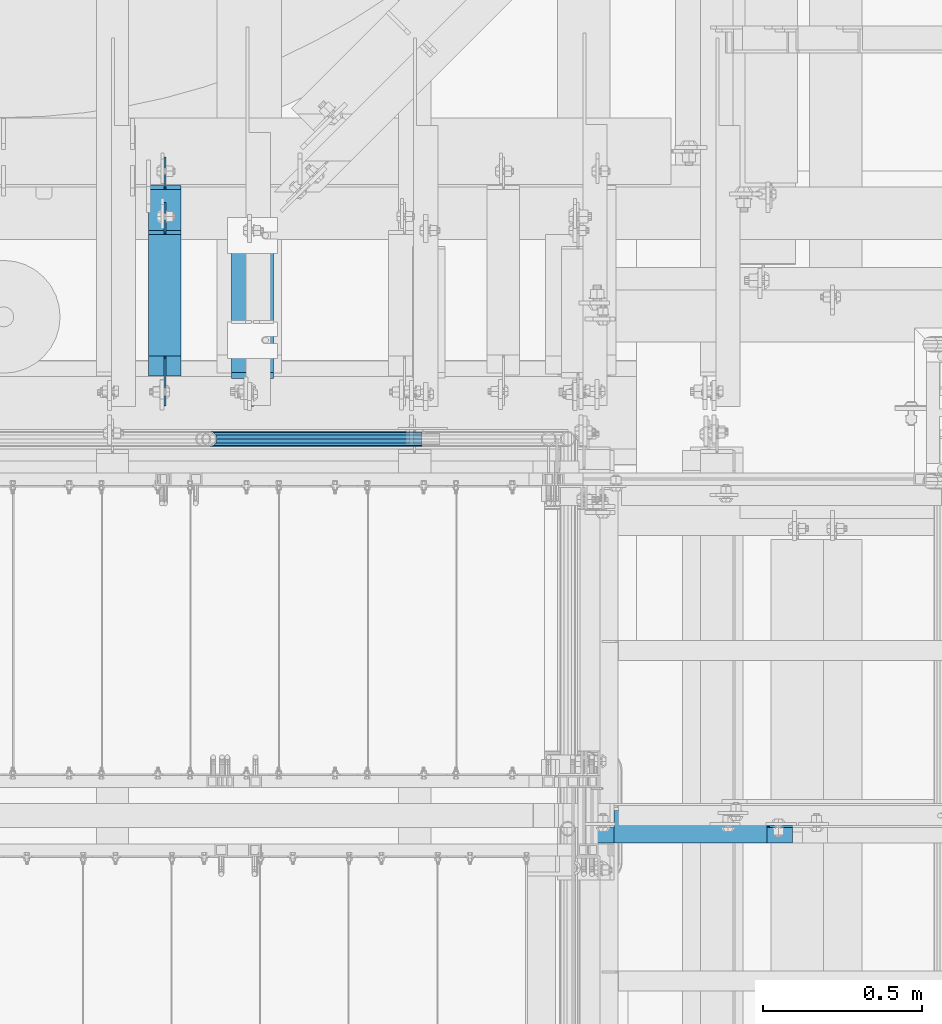
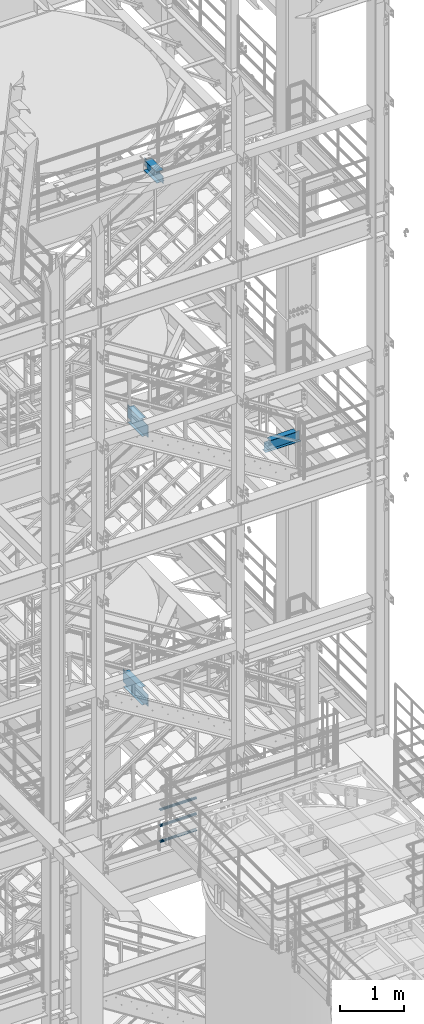
# One storey, part 1194 of 1876: 7 beams, 5 elements without a shape of their own.
"""IFC2X3 building model written with IfcOpenShell, lengths in millimetres."""

from ifc_helpers import new_model, si_unit, frame, origin_with_axes, place, context, subcontext, project, spatial, faceted_brep, material, type_object, element, aggregate, save


model = new_model("IFC2X3")

# Units and contexts
model_context = context("Model", 3, precision=1e-05, world=origin_with_axes())
body_context = subcontext(model_context, "Body", "Model", "MODEL_VIEW")
ifc_project = project(units=[si_unit("LENGTHUNIT", "METRE", prefix="MILLI"), si_unit("AREAUNIT", "SQUARE_METRE"), si_unit("VOLUMEUNIT", "CUBIC_METRE"), si_unit("MASSUNIT", "GRAM", prefix="KILO"), si_unit("TIMEUNIT", "SECOND"), si_unit("PLANEANGLEUNIT", "RADIAN"), si_unit("SOLIDANGLEUNIT", "STERADIAN"), si_unit("THERMODYNAMICTEMPERATUREUNIT", "DEGREE_CELSIUS"), si_unit("LUMINOUSINTENSITYUNIT", "LUMEN")], contexts=[model_context])

# Site, building, storey
site_placement = place(None, origin_with_axes())
site = spatial("IfcSite", under=ifc_project, at=site_placement, CompositionType="ELEMENT")
building_placement = place(site_placement, origin_with_axes())
building = spatial("IfcBuilding", under=site, at=building_placement, Name="Undefined", CompositionType="ELEMENT")
storey_placement = place(building_placement, origin_with_axes())
storey = spatial("IfcBuildingStorey", under=building, at=storey_placement, Name="Undefined", CompositionType="ELEMENT", Elevation=0.0)

# Assembly, beam
assembly_1_placement = place(storey_placement, origin_with_axes())
assembly_1 = element("IfcElementAssembly", 1, at=assembly_1_placement, inside=storey, Name="BEAM", AssemblyPlace="NOTDEFINED", PredefinedType="RIGID_FRAME")
ifc_material_1 = material(Name="STEEL/A992")
beam_type_1 = type_object("IfcBeamType", Name="W8X15", PredefinedType="NOTDEFINED")
beam_1_placement = place(assembly_1_placement, frame((6273.79999930564, -5876.925, 13206.4125), z_axis=(0.0, 0.0, 1.0), x_axis=(1.0, 0.0, 0.0)))
beam_1 = element("IfcBeam", 2, at=beam_1_placement, type_object=beam_type_1, material=ifc_material_1, Name="BEAM", ObjectType="W8X15", context=body_context, shape_type="Brep", body=[
    faceted_brep([(552.450000694359, -50.8000000000002, 103.1875), (552.450000694359, -50.8000000000002, 95.25), (552.450000694359, -3.17500000000018, 95.25), (552.450000694359, -3.17500000000018, 87.3124998092626), (552.450000694359, 3.17500000000018, 87.3124998092626), (552.450000694359, 3.17500000000018, 95.25), (552.450000694359, 50.8000000000002, 95.25), (552.450000694359, 50.8000000000002, 103.1875), (553.416730616947, -3.17500000000018, 82.4524202912162), (553.416730616947, 3.17500000000018, 82.4524202912162), (556.169744517425, -3.17500000000018, 78.3322438230625), (556.169744517425, 3.17500000000018, 78.3322438230625), (560.289920985579, -3.17500000000018, 75.579229922585), (560.289920985579, 3.17500000000018, 75.579229922585), (565.150000503624, -3.17500000000018, 74.6124999999975), (565.150000503624, 3.17500000000018, 74.6124999999975), (631.825000694358, -3.17500000000018, 74.6124999999975), (631.825000694358, 3.17500000000018, 74.6124999999975), (69.8500006943577, -50.8000000000002, 103.1875), (69.8500006943577, 50.8000000000002, 103.1875), (69.8500006943577, 50.8000000000002, 95.25), (69.8500006943577, 3.17500000000018, 95.25), (69.8500006943577, 3.17500000000018, 87.3124998092626), (69.8500006943577, -3.17500000000018, 87.3124998092626), (69.8500006943577, -3.17500000000018, 95.25), (69.8500006943577, -50.8000000000002, 95.25), (68.8832707717702, 3.17500000000018, 82.4524202912162), (68.8832707717702, -3.17500000000018, 82.4524202912162), (66.1302568712917, 3.17500000000018, 78.3322438230625), (66.1302568712917, -3.17500000000018, 78.3322438230625), (62.0100804031381, 3.17500000000018, 75.579229922585), (62.0100804031381, -3.17500000000018, 75.579229922585), (57.1500008850926, 3.17500000000018, 74.6124999999975), (57.1500008850926, -3.17500000000018, 74.6124999999975), (-9.52499930564227, 3.17500000000018, 74.6124999999975), (-9.52499930564227, -3.17500000000018, 74.6124999999975), (-9.52499930564227, 3.17500000000018, -95.25), (-9.52499930564227, 50.8000000000002, -95.25), (-9.52499930564227, 50.8000000000002, -103.1875), (-9.52499930564227, -50.8000000000002, -103.1875), (-9.52499930564227, -50.8000000000002, -95.25), (-9.52499930564227, -3.17500000000018, -95.25), (631.825000694358, 3.17500000000018, -95.25), (631.825000694358, 50.8000000000002, -95.25), (631.825000694358, 50.8000000000002, -103.1875), (631.825000694358, -50.8000000000002, -103.1875), (631.825000694358, -50.8000000000002, -95.25), (631.825000694358, -3.17500000000018, -95.25)], [[[0, 1, 2, 3, 4, 5, 6, 7]], [[8, 9, 4, 3]], [[10, 11, 9, 8]], [[12, 13, 11, 10]], [[14, 15, 13, 12]], [[16, 17, 15, 14]], [[18, 19, 20, 21, 22, 23, 24, 25]], [[23, 22, 26, 27]], [[27, 26, 28, 29]], [[29, 28, 30, 31]], [[31, 30, 32, 33]], [[33, 32, 34, 35]], [[36, 37, 38, 39, 40, 41, 35, 34]], [[37, 36, 42, 43]], [[38, 37, 43, 44]], [[39, 38, 44, 45]], [[40, 39, 45, 46]], [[41, 40, 46, 47]], [[12, 10, 8, 3, 2, 24, 23, 27, 29, 31, 33, 35, 41, 47, 16, 14]], [[25, 24, 2, 1]], [[18, 25, 1, 0]], [[19, 18, 0, 7]], [[20, 19, 7, 6]], [[21, 20, 6, 5]], [[42, 36, 34, 32, 30, 28, 26, 22, 21, 5, 4, 9, 11, 13, 15, 17]], [[47, 46, 45, 44, 43, 42, 17, 16]]]),
])
aggregate(assembly_1, [beam_1])

# Assembly, beams
assembly_2_placement = place(storey_placement, origin_with_axes())
assembly_2 = element("IfcElementAssembly", 3, at=assembly_2_placement, inside=storey, Name="RAIL", AssemblyPlace="NOTDEFINED", PredefinedType="RIGID_FRAME")
ifc_material_2 = material()
beam_type_2 = type_object("IfcBeamType", Name="PIPE1-1/2SCH40", PredefinedType="NOTDEFINED")
beam_2_placement = place(assembly_2_placement, frame((5067.30000007784, -4654.55000114548, 5292.725), z_axis=(0.0, 0.0, 1.0), x_axis=(1.0, 0.0, 0.0)))
beam_2 = element("IfcBeam", 4, at=beam_2_placement, type_object=beam_type_2, material=ifc_material_2, Name="RAIL", ObjectType="PIPE1-1/2SCH40", context=body_context, shape_type="Brep", body=[
    faceted_brep([(0.0, 24.1299999999992, 0.0), (12.0650000000064, 20.8971929933177, -12.0649999999987), (12.0650000000064, 20.8971929933177, 12.0649999999987), (12.0650000000064, -20.8971929933177, 12.0649999999987), (12.0650000000064, -20.8971929933177, -12.0649999999987), (0.0, -24.1299999999992, 0.0), (20.8971929933249, -12.0650000000005, 20.8971929933177), (20.8971929933249, -12.0650000000005, 15.8661214311796), (15.2545715621445, -17.7076214311801, 10.2235000000001), (12.5151929933249, -20.4470000000001, 0.0), (15.2545715621445, -17.7076214311801, -10.2235000000001), (20.8971929933249, -12.0650000000005, -15.8661214311796), (20.8971929933249, -12.0650000000005, -20.8971929933177), (24.1300000000063, 0.0, -20.4470000000001), (24.1300000000063, 0.0, -24.130000000001), (21.3906214311868, -10.2235000000001, -17.7076214311819), (21.3906214311868, 10.2235000000001, -17.7076214311819), (20.8971929933249, 12.0650000000005, -15.8661214311796), (20.8971929933249, 12.0650000000005, -20.8971929933177), (15.2545715621445, 17.7076214311801, -10.2235000000001), (12.5151929933249, 20.4470000000001, 0.0), (15.2545715621445, 17.7076214311801, 10.2235000000001), (20.8971929933249, 12.0650000000005, 15.8661214311796), (20.8971929933249, 12.0650000000005, 20.8971929933177), (21.3906214311868, 10.2235000000001, 17.7076214311819), (24.1300000000064, 0.0, 20.4470000000001), (24.1300000000064, 0.0, 24.130000000001), (21.3906214311868, -10.2235000000001, 17.7076214311819), (671.512999999998, -24.1300000000001, 0.0), (671.512999999998, -20.8971929933186, 12.0649999999996), (671.512999999998, -12.0649999999996, 20.8971929933186), (671.512999999998, 0.0, 24.1300000000001), (671.512999999998, -12.0649999999996, -20.8971929933186), (671.512999999998, -20.8971929933186, -12.0649999999996), (671.512999999998, 0.0, -24.1300000000001), (671.512999999998, 12.0649999999996, -20.8971929933186), (671.512999999998, 20.8971929933186, -12.0649999999996), (671.512999999998, 24.1300000000001, 0.0), (671.512999999998, 20.8971929933186, 12.0649999999996), (671.512999999998, 12.0649999999996, 20.8971929933186), (671.512999999998, -10.2235000000001, 17.7076214311801), (671.512999999998, 0.0, 20.4470000000001), (671.512999999998, 10.2235000000001, 17.7076214311801), (671.512999999998, 17.7076214311801, 10.2235000000001), (671.512999999998, 20.4470000000001, 0.0), (671.512999999998, 17.7076214311801, -10.2235000000001), (671.512999999998, 10.2235000000001, -17.7076214311801), (671.512999999998, 0.0, -20.4470000000001), (671.512999999998, -10.2235000000001, -17.7076214311801), (671.512999999998, -17.7076214311801, -10.2235000000001), (671.512999999998, -20.4470000000001, 0.0), (671.512999999998, -17.7076214311801, 10.2235000000001)], [[[0, 1, 2]], [[3, 4, 5]], [[6, 7, 8, 9, 10, 11, 12, 4, 3]], [[13, 14, 12, 11, 15]], [[16, 17, 18, 14, 13]], [[2, 1, 18, 17, 19, 20, 21, 22, 23]], [[23, 22, 24, 25, 26]], [[26, 25, 27, 7, 6]], [[28, 29, 3, 5]], [[29, 30, 6, 3]], [[30, 31, 26, 6]], [[32, 33, 4, 12]], [[34, 32, 12, 14]], [[35, 34, 14, 18]], [[36, 35, 18, 1]], [[37, 36, 1, 0]], [[38, 37, 0, 2]], [[39, 38, 2, 23]], [[31, 39, 23, 26]], [[33, 28, 5, 4]], [[32, 34, 35, 36, 37, 38, 39, 31, 30, 29, 28, 33], [40, 41, 42, 43, 44, 45, 46, 47, 48, 49, 50, 51]], [[42, 41, 25, 24]], [[21, 43, 42, 24, 22]], [[44, 43, 21, 20]], [[45, 44, 20, 19]], [[46, 45, 19, 17, 16]], [[47, 46, 16, 13]], [[48, 47, 13, 15]], [[10, 49, 48, 15, 11]], [[50, 49, 10, 9]], [[51, 50, 9, 8]], [[40, 51, 8, 7, 27]], [[41, 40, 27, 25]]]),
])
beam_3_placement = place(assembly_2_placement, frame((5740.40000007784, -4654.55000114548, 5597.52500000001), z_axis=(0.0, 0.0, -1.0), x_axis=(-1.0, 0.0, 0.0)))
beam_3 = element("IfcBeam", 5, at=beam_3_placement, type_object=beam_type_2, material=ifc_material_2, Name="RAIL", ObjectType="PIPE1-1/2SCH40", context=body_context, shape_type="Brep", body=[
    faceted_brep([(652.202807006674, -12.0649999999996, 20.8971929933186), (652.202807006674, -12.0650000000296, 15.8661214311505), (651.709378568804, -10.2235000000001, 17.7076214311801), (648.969999999992, 0.0, 20.4470000000001), (648.969999999992, 0.0, 24.1300000000001), (651.709378568819, 10.2235000000001, 17.7076214311801), (652.202807006674, 12.0649999999696, 15.8661214312106), (652.202807006674, 12.0649999999996, 20.8971929933186), (673.099999999999, 24.1300000000001, 0.0), (661.034999999993, 20.8971929933186, 12.0649999999996), (661.034999999993, 20.8971929933186, -12.0649999999996), (657.845428437884, 17.7076214311801, 10.2235000000001), (660.584807006704, 20.4470000000001, 0.0), (657.845428437884, 17.7076214311801, -10.2235000000001), (652.202807006674, 12.0649999999696, -15.8661214312106), (652.202807006674, 12.0649999999996, -20.8971929933186), (651.709378568819, 10.2235000000001, -17.7076214311801), (648.969999999992, 0.0, -20.4470000000001), (648.969999999992, 0.0, -24.1300000000001), (652.202807006674, -12.0650000000296, -15.8661214311505), (652.202807006674, -12.0649999999996, -20.8971929933186), (651.709378568804, -10.2235000000001, -17.7076214311801), (673.099999999992, -24.1300000000301, 0.0), (661.034999999993, -20.8971929933186, -12.0649999999996), (661.034999999993, -20.8971929933186, 12.0649999999996), (657.845428437824, -17.7076214311801, -10.2235000000001), (660.584807006644, -20.4470000000001, 0.0), (657.845428437824, -17.7076214311801, 10.2235000000001), (1.58700000000044, -20.8971929933186, -12.0649999999996), (1.58700000000044, -12.0649999999996, -20.8971929933186), (1.58700000000044, 0.0, -24.1300000000001), (1.58700000000044, 12.0649999999996, -20.8971929933186), (1.58700000000044, 20.8971929933186, -12.0649999999996), (1.58700000000044, 24.1300000000001, 0.0), (1.58700000000044, 20.8971929933186, 12.0649999999996), (1.58700000000044, 12.0649999999996, 20.8971929933186), (1.58700000000044, 0.0, 24.1300000000001), (1.58700000000044, -12.0649999999996, 20.8971929933186), (1.58700000000044, -20.8971929933186, 12.0649999999996), (1.58700000000044, -24.1300000000001, 0.0), (1.58700000000044, -17.7076214311801, -10.2235000000001), (1.58700000000044, -10.2235000000001, -17.7076214311801), (1.58700000000044, 0.0, -20.4470000000001), (1.58700000000044, 10.2235000000001, -17.7076214311801), (1.58700000000044, 17.7076214311801, -10.2235000000001), (1.58700000000044, 20.4470000000001, 0.0), (1.58700000000044, 17.7076214311801, 10.2235000000001), (1.58700000000044, 10.2235000000001, 17.7076214311801), (1.58700000000044, 0.0, 20.4470000000001), (1.58700000000044, -10.2235000000001, 17.7076214311801), (1.58700000000044, -17.7076214311801, 10.2235000000001), (1.58700000000044, -20.4470000000001, 0.0)], [[[0, 1, 2, 3, 4]], [[4, 3, 5, 6, 7]], [[8, 9, 10]], [[7, 6, 11, 12, 13, 14, 15, 10, 9]], [[16, 17, 18, 15, 14]], [[19, 20, 18, 17, 21]], [[22, 23, 24]], [[24, 23, 20, 19, 25, 26, 27, 1, 0]], [[28, 29, 20, 23]], [[29, 30, 18, 20]], [[30, 31, 15, 18]], [[31, 32, 10, 15]], [[32, 33, 8, 10]], [[33, 34, 9, 8]], [[34, 35, 7, 9]], [[35, 36, 4, 7]], [[36, 37, 0, 4]], [[37, 38, 24, 0]], [[38, 39, 22, 24]], [[39, 28, 23, 22]], [[38, 37, 36, 35, 34, 33, 32, 31, 30, 29, 28, 39], [40, 41, 42, 43, 44, 45, 46, 47, 48, 49, 50, 51]], [[40, 51, 26, 25]], [[21, 41, 40, 25, 19]], [[42, 41, 21, 17]], [[43, 42, 17, 16]], [[44, 43, 16, 14, 13]], [[45, 44, 13, 12]], [[46, 45, 12, 11]], [[5, 47, 46, 11, 6]], [[48, 47, 5, 3]], [[49, 48, 3, 2]], [[50, 49, 2, 1, 27]], [[51, 50, 27, 26]]]),
])
beam_4_placement = place(assembly_2_placement, frame((5740.40000007784, -4654.55000114548, 5902.32500000001), z_axis=(0.0, 0.0, -1.0), x_axis=(-1.0, 0.0, 0.0)))
beam_4 = element("IfcBeam", 6, at=beam_4_placement, type_object=beam_type_2, material=ifc_material_2, Name="RAIL", ObjectType="PIPE1-1/2SCH40", context=body_context, shape_type="Brep", body=[
    faceted_brep([(652.202807006674, -12.0649999999996, 20.8971929933186), (652.202807006674, -12.0650000000296, 15.8661214311505), (651.709378568804, -10.2235000000001, 17.7076214311801), (648.969999999992, 0.0, 20.4470000000001), (648.969999999992, 0.0, 24.1300000000001), (651.709378568819, 10.2235000000001, 17.7076214311801), (652.202807006674, 12.0649999999696, 15.8661214312106), (652.202807006674, 12.0649999999996, 20.8971929933186), (673.099999999999, 24.1300000000001, 0.0), (661.034999999993, 20.8971929933186, 12.0649999999996), (661.034999999993, 20.8971929933186, -12.0649999999996), (657.845428437884, 17.7076214311801, 10.2235000000001), (660.584807006704, 20.4470000000001, 0.0), (657.845428437884, 17.7076214311801, -10.2235000000001), (652.202807006674, 12.0649999999696, -15.8661214312106), (652.202807006674, 12.0649999999996, -20.8971929933186), (651.709378568819, 10.2235000000001, -17.7076214311801), (648.969999999992, 0.0, -20.4470000000001), (648.969999999992, 0.0, -24.1300000000001), (652.202807006674, -12.0650000000296, -15.8661214311505), (652.202807006674, -12.0649999999996, -20.8971929933186), (651.709378568804, -10.2235000000001, -17.7076214311801), (673.099999999992, -24.1300000000301, 0.0), (661.034999999993, -20.8971929933186, -12.0649999999996), (661.034999999993, -20.8971929933186, 12.0649999999996), (657.845428437824, -17.7076214311801, -10.2235000000001), (660.584807006644, -20.4470000000001, 0.0), (657.845428437824, -17.7076214311801, 10.2235000000001), (1.58700000000044, -20.8971929933186, -12.0649999999996), (1.58700000000044, -12.0649999999996, -20.8971929933186), (1.58700000000044, 0.0, -24.1300000000001), (1.58700000000044, 12.0649999999996, -20.8971929933186), (1.58700000000044, 20.8971929933186, -12.0649999999996), (1.58700000000044, 24.1300000000001, 0.0), (1.58700000000044, 20.8971929933186, 12.0649999999996), (1.58700000000044, 12.0649999999996, 20.8971929933186), (1.58700000000044, 0.0, 24.1300000000001), (1.58700000000044, -12.0649999999996, 20.8971929933186), (1.58700000000044, -20.8971929933186, 12.0649999999996), (1.58700000000044, -24.1300000000001, 0.0), (1.58700000000044, -17.7076214311801, -10.2235000000001), (1.58700000000044, -10.2235000000001, -17.7076214311801), (1.58700000000044, 0.0, -20.4470000000001), (1.58700000000044, 10.2235000000001, -17.7076214311801), (1.58700000000044, 17.7076214311801, -10.2235000000001), (1.58700000000044, 20.4470000000001, 0.0), (1.58700000000044, 17.7076214311801, 10.2235000000001), (1.58700000000044, 10.2235000000001, 17.7076214311801), (1.58700000000044, 0.0, 20.4470000000001), (1.58700000000044, -10.2235000000001, 17.7076214311801), (1.58700000000044, -17.7076214311801, 10.2235000000001), (1.58700000000044, -20.4470000000001, 0.0)], [[[0, 1, 2, 3, 4]], [[4, 3, 5, 6, 7]], [[8, 9, 10]], [[7, 6, 11, 12, 13, 14, 15, 10, 9]], [[16, 17, 18, 15, 14]], [[19, 20, 18, 17, 21]], [[22, 23, 24]], [[24, 23, 20, 19, 25, 26, 27, 1, 0]], [[28, 29, 20, 23]], [[29, 30, 18, 20]], [[30, 31, 15, 18]], [[31, 32, 10, 15]], [[32, 33, 8, 10]], [[33, 34, 9, 8]], [[34, 35, 7, 9]], [[35, 36, 4, 7]], [[36, 37, 0, 4]], [[37, 38, 24, 0]], [[38, 39, 22, 24]], [[39, 28, 23, 22]], [[38, 37, 36, 35, 34, 33, 32, 31, 30, 29, 28, 39], [40, 41, 42, 43, 44, 45, 46, 47, 48, 49, 50, 51]], [[40, 51, 26, 25]], [[21, 41, 40, 25, 19]], [[42, 41, 21, 17]], [[43, 42, 17, 16]], [[44, 43, 16, 14, 13]], [[45, 44, 13, 12]], [[46, 45, 12, 11]], [[5, 47, 46, 11, 6]], [[48, 47, 5, 3]], [[49, 48, 3, 2]], [[50, 49, 2, 1, 27]], [[51, 50, 27, 26]]]),
])
aggregate(assembly_2, [beam_2, beam_3, beam_4])

# Assembly, beam
assembly_3_placement = place(storey_placement, origin_with_axes())
assembly_3 = element("IfcElementAssembly", 7, at=assembly_3_placement, inside=storey, Name="BEAM", AssemblyPlace="NOTDEFINED", PredefinedType="RIGID_FRAME")
beam_type_3 = type_object("IfcBeamType", Name="W12X16", PredefinedType="NOTDEFINED")
beam_5_placement = place(assembly_3_placement, frame((4927.6, -4572.0, 13157.2), z_axis=(0.0, 0.0, 1.0), x_axis=(0.0, 1.0, 0.0)))
beam_5 = element("IfcBeam", 8, at=beam_5_placement, type_object=beam_type_3, material=ifc_material_1, Name="BEAM", ObjectType="W12X16", context=body_context, shape_type="Brep", body=[
    faceted_brep([(573.881250000001, -3.17500000000018, -146.049999999999), (573.881250000001, -50.8000000000002, -146.049999999999), (573.881250000001, -50.8000000000002, -152.4), (573.881250000001, 50.8000000000002, -152.4), (573.881250000001, 50.8000000000002, -146.049999999999), (573.881250000001, 3.17500000000018, -146.049999999999), (573.881250000001, 3.17500000000018, -139.699999809265), (573.881250000001, -3.17500000000018, -139.699999809265), (574.847979922589, 3.17500000000018, -134.839920291219), (574.847979922589, -3.17500000000018, -134.839920291219), (577.600993823067, 3.17500000000018, -130.719743823065), (577.600993823067, -3.17500000000018, -130.719743823065), (581.72117029122, 3.17500000000018, -127.966729922588), (581.72117029122, -3.17500000000018, -127.966729922588), (586.581249809266, 3.17500000000018, -127.0), (586.581249809266, -3.17500000000018, -127.0), (662.78125, -3.17500000000018, -127.0), (662.78125, 3.17500000000018, -127.0), (179.3875, 3.17500000000018, 146.049999999999), (179.3875, 50.8000000000002, 146.049999999999), (561.181250000001, 50.8000000000002, 146.049999999999), (561.181250000001, 3.17500000000018, 146.049999999999), (115.8875, -3.17500000000018, -139.699999809263), (115.8875, 3.17500000000018, -139.699999809263), (115.8875, 3.17500000000018, -146.049999999999), (115.8875, 50.8000000000002, -146.049999999999), (115.8875, 50.8000000000002, -152.4), (115.8875, -50.8000000000002, -152.4), (115.8875, -50.8000000000002, -146.049999999999), (115.8875, -3.17500000000018, -146.049999999999), (114.920770077412, -3.17500000000018, -134.839920291217), (114.920770077412, 3.17500000000018, -134.839920291217), (112.167756176934, -3.17500000000018, -130.719743823063), (112.167756176934, 3.17500000000018, -130.719743823063), (108.04757970878, -3.17500000000018, -127.966729922586), (108.04757970878, 3.17500000000018, -127.966729922586), (103.187500190735, -3.17500000000018, -126.999999999998), (103.187500190735, 3.17500000000018, -126.999999999998), (20.6374999999998, -3.17500000000018, -126.999999999998), (20.6374999999998, 3.17500000000018, -126.999999999998), (20.6374999999998, -3.17500000000018, 101.600000000002), (20.6374999999998, 3.17500000000018, 101.600000000002), (166.687500190735, -3.17500000000018, 101.600000000002), (166.687500190735, 3.17500000000018, 101.600000000002), (171.54757970878, -3.17500000000018, 102.56672992259), (171.54757970878, 3.17500000000018, 102.56672992259), (175.667756176934, -3.17500000000018, 105.319743823067), (175.667756176934, 3.17500000000018, 105.319743823067), (178.420770077412, -3.17500000000018, 109.439920291221), (178.420770077412, 3.17500000000018, 109.439920291221), (179.3875, -3.17500000000018, 114.299999809267), (179.3875, 3.17500000000018, 114.299999809267), (179.3875, -50.8000000000002, 152.4), (179.3875, 50.8000000000002, 152.4), (179.3875, -3.17500000000018, 146.049999999999), (179.3875, -50.8000000000002, 146.049999999999), (561.181250000001, -3.17500000000018, 146.049999999999), (561.181250000001, -50.8000000000002, 146.049999999999), (561.181250000001, -50.8000000000002, 152.4), (561.181250000001, 50.8000000000002, 152.4), (561.181250000001, -3.17500000000018, 133.349999809265), (561.181250000001, 3.17500000000018, 133.349999809265), (562.147979922589, -3.17500000000018, 128.489920291218), (562.147979922589, 3.17500000000018, 128.489920291218), (564.900993823067, -3.17500000000018, 124.369743823065), (564.900993823067, 3.17500000000018, 124.369743823065), (569.021170291221, -3.17500000000018, 121.616729922587), (569.021170291221, 3.17500000000018, 121.616729922587), (573.881249809266, -3.17500000000018, 120.65), (573.881249809266, 3.17500000000018, 120.65), (662.78125, -3.17500000000018, 120.65), (662.78125, 3.17500000000018, 120.65)], [[[0, 1, 2, 3, 4, 5, 6, 7]], [[7, 6, 8, 9]], [[9, 8, 10, 11]], [[11, 10, 12, 13]], [[13, 12, 14, 15]], [[16, 15, 14, 17]], [[18, 19, 20, 21]], [[22, 23, 24, 25, 26, 27, 28, 29]], [[30, 31, 23, 22]], [[32, 33, 31, 30]], [[34, 35, 33, 32]], [[36, 37, 35, 34]], [[38, 39, 37, 36]], [[40, 41, 39, 38]], [[42, 43, 41, 40]], [[44, 45, 43, 42]], [[46, 47, 45, 44]], [[48, 49, 47, 46]], [[50, 51, 49, 48]], [[52, 53, 19, 18, 51, 50, 54, 55]], [[55, 54, 56, 57]], [[52, 55, 57, 58]], [[53, 52, 58, 59]], [[19, 53, 59, 20]], [[58, 57, 56, 60, 61, 21, 20, 59]], [[62, 63, 61, 60]], [[64, 65, 63, 62]], [[66, 67, 65, 64]], [[68, 69, 67, 66]], [[70, 71, 69, 68]], [[71, 70, 16, 17]], [[12, 10, 8, 6, 5, 24, 23, 31, 33, 35, 37, 39, 41, 43, 45, 47, 49, 51, 18, 21, 61, 63, 65, 67, 69, 71, 17, 14]], [[25, 24, 5, 4]], [[26, 25, 4, 3]], [[27, 26, 3, 2]], [[28, 27, 2, 1]], [[29, 28, 1, 0]], [[70, 68, 66, 64, 62, 60, 56, 54, 50, 48, 46, 44, 42, 40, 38, 36, 34, 32, 30, 22, 29, 0, 7, 9, 11, 13, 15, 16]]]),
])
aggregate(assembly_3, [beam_5])

assembly_4_placement = place(storey_placement, origin_with_axes())
assembly_4 = element("IfcElementAssembly", 9, at=assembly_4_placement, inside=storey, Name="BEAM", AssemblyPlace="NOTDEFINED", PredefinedType="RIGID_FRAME")
beam_6_placement = place(assembly_4_placement, frame((4927.6, -4572.0, 8001.0), z_axis=(0.0, 0.0, 1.0), x_axis=(0.0, 1.0, 0.0)))
beam_6 = element("IfcBeam", 10, at=beam_6_placement, type_object=beam_type_3, material=ifc_material_1, Name="BEAM", ObjectType="W12X16", context=body_context, shape_type="Brep", body=[
    faceted_brep([(716.75625, -3.17500000000018, -146.05), (716.75625, -50.8000000000002, -146.05), (716.75625, -50.8000000000002, -152.4), (716.75625, 50.8000000000002, -152.4), (716.75625, 50.8000000000002, -146.05), (716.75625, 3.17500001244935, -146.05), (716.75625, 3.17500003927307, -139.699999809264), (716.75625, -3.17500000000018, -139.699999809264), (717.722979922588, 3.17500003847817, -134.839920291219), (717.722979922588, -3.17500000000018, -134.839920291219), (720.475993823066, 3.17500003779696, -130.719743823065), (720.475993823066, -3.17500000000018, -130.719743823065), (724.59617029122, 3.17500003733312, -127.966729922587), (724.59617029122, -3.17500000000018, -127.966729922587), (729.456249809265, 3.17500003715577, -126.999999999999), (729.456249809265, -3.17500000000018, -126.999999999999), (805.65625, -3.17500000000018, -126.999999999999), (805.65625, 3.17500000000018, -126.999999999999), (181.768749999998, 3.17499999999995, 146.05), (181.768749999998, 50.8, 146.05), (704.05625, 50.8000000000002, 146.05), (704.05625, 3.17500000000018, 146.05), (124.61875, 50.8, -146.05), (124.61875, 50.8, -152.4), (124.61875, 3.17500009536752, -152.4), (124.61875, 3.17500009536752, -146.05), (118.268749999998, 3.17500009536752, -152.4), (118.268749999998, 3.17500008940715, -146.05), (118.268749999998, -3.17499999999995, -139.699999809265), (118.268749999998, 3.17500002616043, -139.699999809265), (118.268749999998, -50.8, -152.4), (118.268749999998, -50.8, -146.05), (118.268749999998, -3.17499999999995, -146.05), (117.302020077411, -3.17499999999995, -134.83992029122), (117.302020077411, 3.17500002537099, -134.83992029122), (114.549006176932, -3.17499999999995, -130.719743823066), (114.549006176932, 3.17500002470138, -130.719743823066), (110.428829708779, -3.17499999999995, -127.966729922588), (110.428829708779, 3.17500002425345, -127.966729922588), (105.568750190733, -3.17499999999995, -127.0), (105.568750190733, 3.17500002409543, -127.0), (23.0187500000002, -3.17499999999995, -127.0), (23.0187500000002, 3.17499999999995, -127.0), (23.0187500000002, -3.17499999999995, 101.6), (23.0187500000002, 3.17499999999995, 101.6), (169.068750190733, -3.17499999999995, 101.6), (169.068750190733, 3.17499998798007, 101.6), (173.928829708779, -3.17499999999995, 102.566729922588), (173.928829708779, 3.17499998782432, 102.566729922588), (178.049006176932, -3.17499999999995, 105.319743823066), (178.049006176932, 3.17499998738072, 105.319743823066), (180.802020077411, -3.17499999999995, 109.43992029122), (180.802020077411, 3.17499998671678, 109.43992029122), (181.768749999998, -3.17499999999995, 114.299999809266), (181.768749999998, 3.17499998593348, 114.299999809266), (181.768749999998, -50.8, 152.4), (181.768749999998, 50.8, 152.4), (181.768749999998, -3.17499999999995, 146.05), (181.768749999998, -50.8, 146.05), (704.05625, -3.17500000000018, 146.05), (704.05625, -50.8000000000002, 146.05), (704.05625, -50.8000000000002, 152.4), (704.05625, 50.8000000000002, 152.4), (704.05625, -3.17500000000018, 133.349999809266), (704.05625, 3.1749999952408, 133.349999809266), (705.022979922588, -3.17500000000018, 128.48992029122), (705.022979922588, 3.17499999601478, 128.48992029122), (707.775993823066, -3.17500000000018, 124.369743823067), (707.775993823066, 3.17499999666416, 124.369743823067), (711.89617029122, -3.17500000000018, 121.616729922588), (711.89617029122, 3.1749999970898, 121.616729922588), (716.756249809265, -3.17500000000018, 120.650000000001), (716.756249809265, 3.17499999722713, 120.650000000001), (805.65625, -3.17500000000018, 120.650000000001), (805.65625, 3.17500000000018, 120.650000000001)], [[[0, 1, 2, 3, 4, 5, 6, 7]], [[7, 6, 8, 9]], [[9, 8, 10, 11]], [[11, 10, 12, 13]], [[13, 12, 14, 15]], [[16, 15, 14, 17]], [[18, 19, 20, 21]], [[22, 23, 24, 25]], [[25, 24, 26, 27]], [[28, 29, 27, 26, 30, 31, 32]], [[33, 34, 29, 28]], [[35, 36, 34, 33]], [[37, 38, 36, 35]], [[39, 40, 38, 37]], [[41, 42, 40, 39]], [[43, 44, 42, 41]], [[45, 46, 44, 43]], [[47, 48, 46, 45]], [[49, 50, 48, 47]], [[51, 52, 50, 49]], [[53, 54, 52, 51]], [[55, 56, 19, 18, 54, 53, 57, 58]], [[58, 57, 59, 60]], [[55, 58, 60, 61]], [[56, 55, 61, 62]], [[19, 56, 62, 20]], [[61, 60, 59, 63, 64, 21, 20, 62]], [[65, 66, 64, 63]], [[67, 68, 66, 65]], [[69, 70, 68, 67]], [[71, 72, 70, 69]], [[73, 74, 72, 71]], [[74, 73, 16, 17]], [[12, 10, 8, 6, 5, 25, 27, 29, 34, 36, 38, 40, 42, 44, 46, 48, 50, 52, 54, 18, 21, 64, 66, 68, 70, 72, 74, 17, 14]], [[22, 25, 5, 4]], [[23, 22, 4, 3]], [[30, 26, 24, 23, 3, 2]], [[31, 30, 2, 1]], [[32, 31, 1, 0]], [[73, 71, 69, 67, 65, 63, 59, 57, 53, 51, 49, 47, 45, 43, 41, 39, 37, 35, 33, 28, 32, 0, 7, 9, 11, 13, 15, 16]]]),
])
aggregate(assembly_4, [beam_6])

assembly_5_placement = place(storey_placement, origin_with_axes())
assembly_5 = element("IfcElementAssembly", 11, at=assembly_5_placement, inside=storey, Name="BEAM", AssemblyPlace="NOTDEFINED", PredefinedType="RIGID_FRAME")
beam_type_4 = type_object("IfcBeamType", Name="W8X18", PredefinedType="NOTDEFINED")
beam_7_placement = place(assembly_5_placement, frame((5203.825, -4572.0, 17880.0125), z_axis=(0.0, 0.0, 1.0), x_axis=(0.0, 1.0, 0.0)))
beam_7 = element("IfcBeam", 12, at=beam_7_placement, type_object=beam_type_4, material=ifc_material_1, Name="BEAM", ObjectType="W8X18", context=body_context, shape_type="Brep", body=[
    faceted_brep([(19.84375, -3.17500000000018, -84.1374999999971), (19.84375, 3.17500000000018, -84.1374999999971), (96.0437501907345, 3.17500002296038, -84.1374999999971), (96.0437501907345, -3.17500000000018, -84.1374999999971), (100.90382970878, 3.17500002319775, -85.1042299225846), (100.90382970878, -3.17500000000018, -85.1042299225846), (105.024006176934, 3.17500002384804, -87.8572438230622), (105.024006176934, -3.17500000000018, -87.8572438230622), (107.777020077412, 3.17500002481211, -91.9774202912158), (107.777020077412, -3.17500000000018, -91.9774202912158), (108.74375, -66.6750000000002, -96.8374998092622), (108.74375, 66.6750000000002, -96.8374998092622), (108.74375, 66.6750000000002, -103.1875), (108.74375, -66.6750000000002, -103.1875), (108.427976654724, -66.6750000000002, -95.25), (108.427976654724, -3.17500000000018, -95.25), (108.427976654724, 3.17500009258674, -95.25), (108.427976654724, 66.6750000000002, -95.25), (504.825000000001, 66.6750000000002, 95.25), (504.825000000001, 3.17500000000018, 95.25), (126.20625, 3.17500000000018, 95.25), (126.20625, 66.6750000000002, 95.25), (113.506250190735, -3.17500000000018, 58.7375000000029), (113.506250190735, 3.17499999062875, 58.7375000000029), (19.84375, 3.17500000000018, 58.7375000000029), (19.84375, -3.17500000000018, 58.7375000000029), (118.366329708781, -3.17500000000018, 59.7042299225905), (118.366329708781, 3.17499999041775, 59.7042299225905), (122.486506176934, -3.17500000000018, 62.457243823068), (122.486506176934, 3.17499998979656, 62.457243823068), (125.239520077413, -3.17500000000018, 66.5774202912216), (125.239520077413, 3.17499998886069, 66.5774202912216), (126.20625, -3.17500000000018, 71.437499809268), (126.20625, 3.17499998775293, 71.437499809268), (504.825000000001, -66.6750000000002, 103.1875), (504.825000000001, 66.6750000000002, 103.1875), (126.20625, 66.6750000000002, 103.1875), (126.20625, -66.6750000000002, 103.1875), (504.825000000001, -66.6750000000002, 95.25), (126.20625, -66.6750000000002, 95.25), (504.825000000001, -3.17500000000018, 95.25), (126.20625, -3.17500000000018, 95.25), (504.825000000001, -3.17500000000018, 84.1374998092615), (504.825000000001, 3.17500000000018, 84.1374998092615), (505.791729922589, -3.17500000000018, 79.2774202912151), (505.791729922589, 3.17500000000018, 79.2774202912151), (508.544743823067, -3.17500000000018, 75.1572438230614), (508.544743823067, 3.17500000000018, 75.1572438230614), (512.664920291221, -3.17500000000018, 72.4042299225839), (512.664920291221, 3.17500000000018, 72.4042299225839), (517.524999809266, -3.17500000000018, 71.4374999999964), (517.524999809266, 3.17500000000018, 71.4374999999964), (612.775, -3.17500000000018, 71.4374999999964), (612.775, 3.17500000000018, 71.4374999999964), (612.775, -3.17500000000018, -80.9625000000051), (612.775, 3.17500000000018, -80.9625000000051), (533.399999809266, -3.17500000000018, -80.9625000000051), (533.399999809266, 3.17500000000018, -80.9625000000051), (528.53992029122, -3.17500000000018, -81.9292299225926), (528.53992029122, 3.17500000000018, -81.9292299225926), (524.419743823067, -3.17500000000018, -84.6822438230702), (524.419743823067, 3.17500000000018, -84.6822438230702), (521.666729922588, -3.17500000000018, -88.8024202912238), (521.666729922588, 3.17500000000018, -88.8024202912238), (520.700000000001, -3.17500000000018, -93.6624998092702), (520.700000000001, 3.17500000000018, -93.6624998092702), (520.700000000001, -3.17500000000018, -95.25), (520.700000000001, -66.6750000000002, -95.25), (520.700000000001, -66.6750000000002, -103.1875), (520.700000000001, 66.6750000000002, -103.1875), (520.700000000001, 66.6750000000002, -95.25), (520.700000000001, 3.17500000000018, -95.25)], [[[0, 1, 2, 3]], [[3, 2, 4, 5]], [[5, 4, 6, 7]], [[7, 6, 8, 9]], [[10, 11, 12, 13]], [[14, 15, 9, 8, 16, 17, 11, 10]], [[18, 19, 20, 21]], [[22, 23, 24, 25]], [[26, 27, 23, 22]], [[28, 29, 27, 26]], [[30, 31, 29, 28]], [[32, 33, 31, 30]], [[34, 35, 36, 37]], [[38, 34, 37, 39]], [[40, 38, 39, 41]], [[37, 36, 21, 20, 33, 32, 41, 39]], [[35, 18, 21, 36]], [[34, 38, 40, 42, 43, 19, 18, 35]], [[44, 45, 43, 42]], [[46, 47, 45, 44]], [[48, 49, 47, 46]], [[50, 51, 49, 48]], [[52, 53, 51, 50]], [[53, 52, 54, 55]], [[54, 56, 57, 55]], [[58, 59, 57, 56]], [[60, 61, 59, 58]], [[62, 63, 61, 60]], [[64, 65, 63, 62]], [[66, 67, 68, 69, 70, 71, 65, 64]], [[69, 68, 13, 12]], [[70, 69, 12, 11, 17]], [[71, 70, 17, 16]], [[6, 4, 2, 1, 24, 23, 27, 29, 31, 33, 20, 19, 43, 45, 47, 49, 51, 53, 55, 57, 59, 61, 63, 65, 71, 16, 8]], [[25, 24, 1, 0]], [[66, 64, 62, 60, 58, 56, 54, 52, 50, 48, 46, 44, 42, 40, 41, 32, 30, 28, 26, 22, 25, 0, 3, 5, 7, 9, 15]], [[67, 66, 15, 14]], [[68, 67, 14, 10, 13]]]),
])
aggregate(assembly_5, [beam_7])

save(model, "model.ifc")
